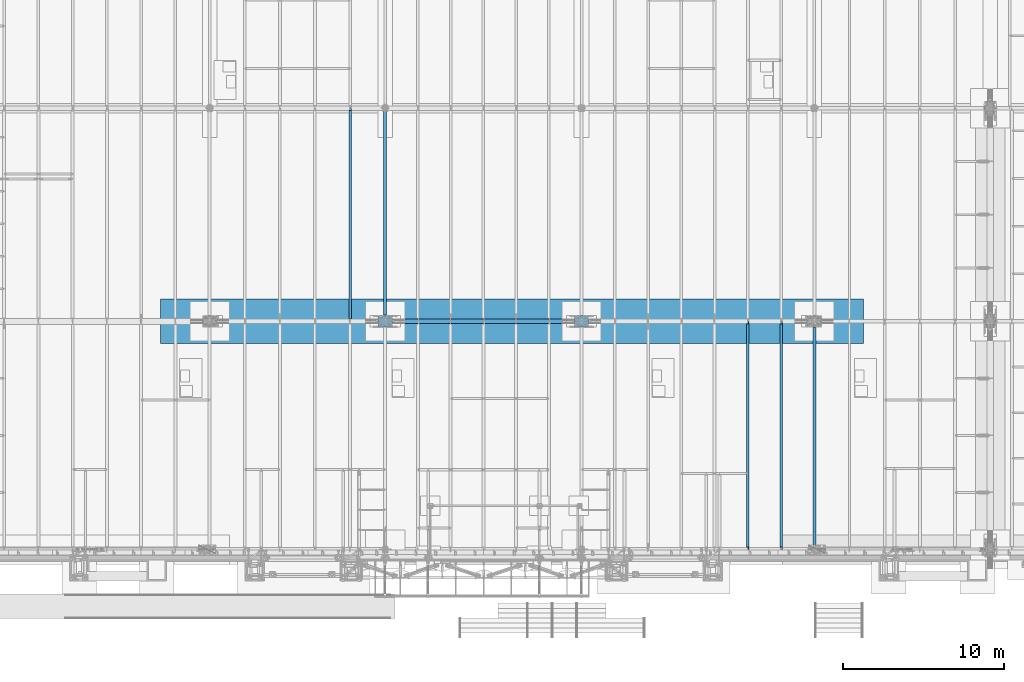
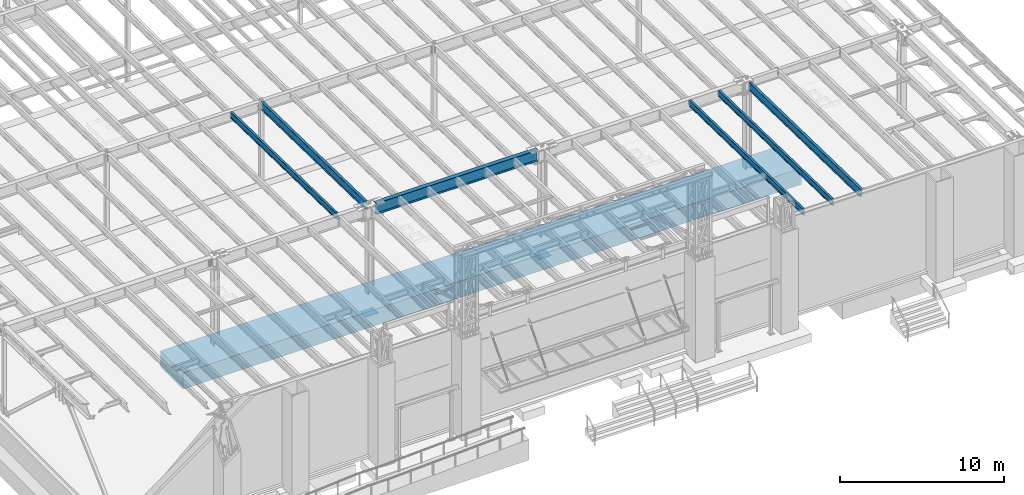
# One storey, part 1067 of 1763: 9 beams, 9 elements without a shape of their own.
"""IFC2X3 building model written with IfcOpenShell, lengths in millimetres."""

from ifc_helpers import new_model, si_unit, frame, origin_with_axes, place, context, subcontext, project, spatial, faceted_brep, material, type_object, element, aggregate, save


model = new_model("IFC2X3")

# Units and contexts
model_context = context("Model", 3, precision=1e-05, world=origin_with_axes())
body_context = subcontext(model_context, "Body", "Model", "MODEL_VIEW")
ifc_project = project(units=[si_unit("LENGTHUNIT", "METRE", prefix="MILLI"), si_unit("AREAUNIT", "SQUARE_METRE"), si_unit("VOLUMEUNIT", "CUBIC_METRE"), si_unit("MASSUNIT", "GRAM", prefix="KILO"), si_unit("TIMEUNIT", "SECOND"), si_unit("PLANEANGLEUNIT", "RADIAN"), si_unit("SOLIDANGLEUNIT", "STERADIAN"), si_unit("THERMODYNAMICTEMPERATUREUNIT", "DEGREE_CELSIUS"), si_unit("LUMINOUSINTENSITYUNIT", "LUMEN")], contexts=[model_context])

# Site, building, storey
site_placement = place(None, origin_with_axes())
site = spatial("IfcSite", under=ifc_project, at=site_placement, CompositionType="ELEMENT")
building_placement = place(site_placement, origin_with_axes())
building = spatial("IfcBuilding", under=site, at=building_placement, Name="Undefined", CompositionType="ELEMENT")
storey_placement = place(building_placement, origin_with_axes())
storey = spatial("IfcBuildingStorey", under=building, at=storey_placement, Name="Undefined", CompositionType="ELEMENT", Elevation=0.0)

# Assembly, beam
assembly_1_placement = place(storey_placement, origin_with_axes())
assembly_1 = element("IfcElementAssembly", 1, at=assembly_1_placement, inside=storey, Name="BEAM", AssemblyPlace="NOTDEFINED", PredefinedType="RIGID_FRAME")
ifc_material_1 = material(Name="STEEL/A992")
beam_type_1 = type_object("IfcBeamType", Name="W18X35", PredefinedType="NOTDEFINED")
beam_1_placement = place(assembly_1_placement, frame((-37014.4944165555, -13720.7116289025, 11979.324245716), z_axis=(0.0, 0.0209013539966291, 0.999781542838788), x_axis=(0.0, 0.999781542776098, -0.0209013569953182)))
beam_1 = element("IfcBeam", 2, at=beam_1_placement, type_object=beam_type_1, material=ifc_material_1, Name="BEAM", ObjectType="W18X35", context=body_context, shape_type="Brep", body=[
    faceted_brep([(14015.111475978, 4.2688297624336, -214.312500004788), (14015.111475978, 4.26866734583018, -225.425000004798), (14015.1114709427, 76.1999999999971, -225.425000004796), (14015.1114709427, 76.1999999999971, -214.312500004788), (14165.6627009912, 4.26875000000291, -215.308088836937), (14165.8742043575, 4.26867789952666, -225.425000004847), (14064.0196871856, 4.26875000000291, -214.312500004802), (14064.0848962425, 4.26875000000291, -217.431666606117), (129.869102983521, 76.1999999999971, -214.312500000213), (130.101420053361, 76.1999999999971, -225.425000000221), (130.101420053361, 4.56874999999854, -225.425000000221), (129.869102983521, 4.56874999999854, -214.312500000213), (30.0675669374232, 4.56874999999854, -225.42500000019), (29.8352498675831, 4.56874999999854, -214.31250000018), (152.354849235744, 3.96875, 214.312500000126), (152.354849235744, 76.1999999999971, 214.312500000126), (14015.1114866801, 76.1999999999971, 214.312499995558), (14015.1114866801, 3.96875, 214.312499995558), (152.354849235751, -76.1999999999971, 225.425000000134), (152.354849235751, 76.1999999999971, 225.425000000134), (152.354849235735, 3.96875, 180.714997673213), (152.354849235735, -3.96875, 180.714997673213), (152.354849235744, -3.96875, 214.312500000126), (152.354849235744, -76.1999999999971, 214.312500000126), (151.388119313144, 3.96875, 175.854918155155), (151.388119313144, -3.96875, 175.854918155155), (148.635105412657, 3.96875, 171.734741686994), (148.635105412657, -3.96875, 171.734741686994), (144.514928944493, 3.96875, 168.98172778651), (144.514928944493, -3.96875, 168.98172778651), (139.654849426437, 3.96875, 168.01499786392), (139.654849426437, -3.96875, 168.01499786392), (21.8423406191578, 3.96875, 168.01499786396), (21.8423406191578, -3.96875, 168.01499786396), (29.8352498675831, 3.96875, -214.31250000018), (30.0675669374232, -76.1999999999971, -225.42500000019), (29.8352498675831, -76.1999999999971, -214.31250000018), (29.8352498675831, -3.96875, -214.31250000018), (14165.8742043575, -76.1999999999971, -225.425000004847), (14165.6418872877, -76.1999999999971, -214.312500004837), (14165.6418872877, -3.96875, -214.312500004837), (14022.9514069713, -3.96875, 168.981727663589), (14018.8312305032, -3.96875, 171.734741564072), (14016.0782166027, -3.96875, 175.854918032239), (14015.1114866801, -3.96875, 180.714997550294), (14015.1114866801, -3.96875, 214.312499995558), (14157.6489780418, -3.96875, 168.014997741), (14027.8114864894, -3.96875, 168.014997740998), (14015.1114866801, -76.1999999999971, 214.312499995558), (14015.1114866801, -76.1999999999971, 225.424999995566), (14015.1114866801, 76.1999999999971, 225.424999995566), (14015.1114866801, 3.96875, 180.714997550294), (14016.0782166027, 3.96875, 175.854918032239), (14018.8312305032, 3.96875, 171.734741564072), (14022.9514069713, 3.96875, 168.981727663589), (14027.8114864894, 3.96875, 168.014997740998), (14157.6489780418, 3.96875, 168.014997741), (14165.6418872877, 3.96875, -214.312500004837), (14165.6418872877, 4.26875000000291, -214.312500004837)], [[[0, 1, 2, 3]], [[4, 5, 1, 0, 6, 7]], [[8, 9, 10, 11]], [[11, 10, 12, 13]], [[14, 15, 16, 17]], [[18, 19, 15, 14, 20, 21, 22, 23]], [[21, 20, 24, 25]], [[25, 24, 26, 27]], [[27, 26, 28, 29]], [[29, 28, 30, 31]], [[31, 30, 32, 33]], [[34, 13, 12, 35, 36, 37, 33, 32]], [[36, 35, 38, 39]], [[37, 36, 39, 40]], [[41, 42, 43, 44, 45, 22, 21, 25, 27, 29, 31, 33, 37, 40, 46, 47]], [[23, 22, 45, 48]], [[18, 23, 48, 49]], [[19, 18, 49, 50]], [[15, 19, 50, 16]], [[49, 48, 45, 44, 51, 17, 16, 50]], [[43, 52, 51, 44]], [[42, 53, 52, 43]], [[41, 54, 53, 42]], [[47, 55, 54, 41]], [[46, 56, 55, 47]], [[57, 34, 32, 30, 28, 26, 24, 20, 14, 17, 51, 52, 53, 54, 55, 56]], [[58, 4, 7, 6]], [[3, 8, 11, 13, 34, 57, 58, 6, 0]], [[9, 8, 3, 2]], [[38, 35, 12, 10, 9, 2, 1, 5]], [[58, 57, 56, 46, 40, 39, 38, 5, 4]]]),
])
aggregate(assembly_1, [beam_1])

assembly_2_placement = place(storey_placement, origin_with_axes())
assembly_2 = element("IfcElementAssembly", 3, at=assembly_2_placement, inside=storey, Name="BEAM", AssemblyPlace="NOTDEFINED", PredefinedType="RIGID_FRAME")
beam_2_placement = place(assembly_2_placement, frame((-39079.1515594126, -13720.7116289377, 11979.324245716), z_axis=(0.0, 0.0209013539966291, 0.999781542838788), x_axis=(0.0, 0.999781542776098, -0.0209013569953182)))
beam_2 = element("IfcBeam", 4, at=beam_2_placement, type_object=beam_type_1, material=ifc_material_1, Name="BEAM", ObjectType="W18X35", context=body_context, shape_type="Brep", body=[
    faceted_brep([(14015.111475978, 4.2688297624336, -214.312500004788), (14015.111475978, 4.26866734583018, -225.425000004798), (14015.1114709427, 76.1999999999971, -225.425000004796), (14015.1114709427, 76.1999999999971, -214.312500004788), (14165.6418873229, 4.26884030015208, -214.312500004839), (14165.8742043575, 4.26867789952666, -225.425000004847), (129.869102983521, 76.1999999999971, -214.312500000213), (130.101420053361, 76.1999999999971, -225.425000000221), (130.101420053361, 4.56874999999854, -225.425000000221), (129.869102983521, 4.56874999999854, -214.312500000213), (30.0675669374232, 4.56874999999854, -225.42500000019), (29.8352498675831, 4.56874999999854, -214.31250000018), (152.354849235744, 3.96875, 214.312500000126), (152.354849235744, 76.1999999999971, 214.312500000126), (14015.1114866801, 76.1999999999971, 214.312499995558), (14015.1114866801, 3.96875, 214.312499995558), (152.354849235751, -76.1999999999971, 225.425000000134), (152.354849235751, 76.1999999999971, 225.425000000134), (152.354849235735, 3.96875, 180.714997673213), (152.354849235735, -3.96875, 180.714997673213), (152.354849235744, -3.96875, 214.312500000126), (152.354849235744, -76.1999999999971, 214.312500000126), (151.388119313144, 3.96875, 175.854918155155), (151.388119313144, -3.96875, 175.854918155155), (148.635105412657, 3.96875, 171.734741686994), (148.635105412657, -3.96875, 171.734741686994), (144.514928944493, 3.96875, 168.98172778651), (144.514928944493, -3.96875, 168.98172778651), (139.654849426437, 3.96875, 168.01499786392), (139.654849426437, -3.96875, 168.01499786392), (21.8423406191578, 3.96875, 168.01499786396), (21.8423406191578, -3.96875, 168.01499786396), (29.8352498675831, 3.96875, -214.31250000018), (30.0675669374232, -76.1999999999971, -225.42500000019), (29.8352498675831, -76.1999999999971, -214.31250000018), (29.8352498675831, -3.96875, -214.31250000018), (14165.8742043575, -76.1999999999971, -225.425000004847), (14165.6418872877, -76.1999999999971, -214.312500004837), (14165.6418872877, -3.96875, -214.312500004837), (14022.9514069713, -3.96875, 168.981727663589), (14018.8312305032, -3.96875, 171.734741564072), (14016.0782166027, -3.96875, 175.854918032239), (14015.1114866801, -3.96875, 180.714997550294), (14015.1114866801, -3.96875, 214.312499995558), (14157.6489780418, -3.96875, 168.014997741), (14027.8114864894, -3.96875, 168.014997740998), (14015.1114866801, -76.1999999999971, 214.312499995558), (14015.1114866801, -76.1999999999971, 225.424999995566), (14015.1114866801, 76.1999999999971, 225.424999995566), (14015.1114866801, 3.96875, 180.714997550294), (14016.0782166027, 3.96875, 175.854918032239), (14018.8312305032, 3.96875, 171.734741564072), (14022.9514069713, 3.96875, 168.981727663589), (14027.8114864894, 3.96875, 168.014997740998), (14157.6489780418, 3.96875, 168.014997741), (14165.6418872877, 3.96875, -214.312500004837)], [[[0, 1, 2, 3]], [[4, 5, 1, 0]], [[6, 7, 8, 9]], [[9, 8, 10, 11]], [[12, 13, 14, 15]], [[16, 17, 13, 12, 18, 19, 20, 21]], [[19, 18, 22, 23]], [[23, 22, 24, 25]], [[25, 24, 26, 27]], [[27, 26, 28, 29]], [[29, 28, 30, 31]], [[32, 11, 10, 33, 34, 35, 31, 30]], [[34, 33, 36, 37]], [[35, 34, 37, 38]], [[39, 40, 41, 42, 43, 20, 19, 23, 25, 27, 29, 31, 35, 38, 44, 45]], [[21, 20, 43, 46]], [[16, 21, 46, 47]], [[17, 16, 47, 48]], [[13, 17, 48, 14]], [[47, 46, 43, 42, 49, 15, 14, 48]], [[41, 50, 49, 42]], [[40, 51, 50, 41]], [[39, 52, 51, 40]], [[45, 53, 52, 39]], [[44, 54, 53, 45]], [[55, 32, 30, 28, 26, 24, 22, 18, 12, 15, 49, 50, 51, 52, 53, 54]], [[3, 6, 9, 11, 32, 55, 4, 0]], [[7, 6, 3, 2]], [[36, 33, 10, 8, 7, 2, 1, 5]], [[55, 54, 44, 38, 37, 36, 5, 4]]]),
])
aggregate(assembly_2, [beam_2])

assembly_3_placement = place(storey_placement, origin_with_axes())
assembly_3 = element("IfcElementAssembly", 5, at=assembly_3_placement, inside=storey, Name="BEAM", AssemblyPlace="NOTDEFINED", PredefinedType="RIGID_FRAME")
beam_type_2 = type_object("IfcBeamType", Name="W18X40", PredefinedType="NOTDEFINED")
beam_3_placement = place(assembly_3_placement, frame((-63773.7572736983, 452.455130930327, 11681.4332640109), z_axis=(0.0, 0.0209013539966291, 0.999781542838788), x_axis=(0.0, 0.999781542776098, -0.0209013569953182)))
beam_3 = element("IfcBeam", 6, at=beam_3_placement, type_object=beam_type_2, material=ifc_material_1, Name="BEAM", ObjectType="W18X40", context=body_context, shape_type="Brep", body=[
    faceted_brep([(29.0743924101943, -3.96875, -214.31250000018), (29.3398976328791, -3.96867297649442, -227.01250000019), (172.24808792756, -3.9686593998631, -227.012500000241), (172.248087927576, -3.96875, -214.312500000231), (172.2480947897, -76.1999999999971, -214.312500000231), (172.248094789697, -76.1999999999971, -227.012500000241), (13125.1458004226, 4.26884714065818, -214.312500004715), (13125.1458004227, 4.268649864287, -227.012500004723), (13125.1457929416, 76.1999999999971, -227.012500004725), (13125.1457929416, 76.1999999999971, -214.312500004715), (172.248086396876, 76.1999999999971, -227.012500000241), (172.24808639688, 76.1999999999971, -214.312500000231), (172.248093258896, 3.96884671709995, -227.012500000241), (172.248093258908, 3.96865936378163, -214.312500001566), (80.1509976836787, 3.96924991607375, -227.01250000021), (79.8854924610018, 3.96875, -214.3125000002), (29.3398976328791, 3.96924991607375, -227.01250000019), (29.0743924101943, 3.96875, -214.31250000018), (172.248085922071, 3.96875, 214.312500000111), (172.248085922071, 76.1999999999971, 214.312500000111), (13088.6333065581, 76.1999999999971, 214.31249999564), (13088.6333065581, 3.96875, 214.31249999564), (13226.4637071899, 3.96875, -214.312500004749), (28.6761568530486, 3.96875, -195.263565576959), (21.0428594241718, 3.96875, 169.862499999928), (159.54808611285, 3.96875, 169.86249999993), (164.408165630896, 3.96875, 170.829229922516), (168.52834209905, 3.96875, 173.582243823001), (171.281355999526, 3.96875, 177.702420291163), (172.248085922111, 3.96875, 182.562499809223), (13088.6333065582, 3.96875, 195.002501414689), (13089.6000364807, 3.96875, 190.142421896631), (13092.3530503812, 3.96875, 186.022245428465), (13096.4732268494, 3.96875, 183.269231527978), (13101.3333063674, 3.96875, 182.302501605383), (13218.1721044876, 3.96875, 182.302501605345), (13226.4637071899, 4.26885767801286, -214.312500004749), (13226.7292124126, 4.26866042923211, -227.012500004759), (13218.1721044876, -3.96875, 182.302501605345), (13226.4637071899, -3.96875, -214.312500004749), (13226.4637071899, -76.1999999999971, -214.312500004749), (13226.7292124126, -76.1999999999971, -227.012500004759), (28.6761593004586, -3.96875, -195.263682644741), (21.0428594241718, -3.96875, 169.862499999928), (159.54808611285, -3.96875, 169.86249999993), (164.408165630896, -3.96875, 170.829229922516), (168.52834209905, -3.96875, 173.582243823001), (171.281355999526, -3.96875, 177.702420291163), (172.248085922111, -3.96875, 182.562499809223), (172.24808592207, -76.1999999999971, 227.012500000121), (172.24808592207, 76.1999999999971, 227.012500000121), (172.248085922071, -3.96875, 214.312500000111), (172.248085922071, -76.1999999999971, 214.312500000111), (13088.6333065581, -3.96875, 214.31249999564), (13088.6333065581, -76.1999999999971, 214.31249999564), (13088.6333065581, -76.1999999999971, 227.01249999565), (13088.6333065581, 76.1999999999971, 227.01249999565), (13088.6333065582, -3.96875, 195.002501414689), (13089.6000364807, -3.96875, 190.142421896631), (13092.3530503812, -3.96875, 186.022245428465), (13096.4732268494, -3.96875, 183.269231527978), (13101.3333063674, -3.96875, 182.302501605383)], [[[0, 1, 2, 3]], [[4, 3, 2, 5]], [[6, 7, 8, 9]], [[10, 11, 9, 8]], [[11, 10, 12, 13]], [[13, 12, 14, 15]], [[16, 17, 15, 14]], [[18, 19, 20, 21]], [[22, 13, 15, 17, 23, 24, 25, 26, 27, 28, 29, 18, 21, 30, 31, 32, 33, 34, 35]], [[9, 11, 13, 22, 36, 6]], [[37, 7, 6, 36]], [[22, 35, 38, 39, 40, 41, 37, 36]], [[41, 40, 4, 5]], [[1, 16, 14, 12, 10, 8, 7, 37, 41, 5, 2]], [[42, 43, 24, 23, 17, 16, 1, 0]], [[44, 25, 24, 43]], [[45, 26, 25, 44]], [[46, 27, 26, 45]], [[47, 28, 27, 46]], [[48, 29, 28, 47]], [[49, 50, 19, 18, 29, 48, 51, 52]], [[52, 51, 53, 54]], [[49, 52, 54, 55]], [[50, 49, 55, 56]], [[19, 50, 56, 20]], [[55, 54, 53, 57, 30, 21, 20, 56]], [[58, 31, 30, 57]], [[59, 32, 31, 58]], [[60, 33, 32, 59]], [[61, 34, 33, 60]], [[38, 35, 34, 61]], [[60, 59, 58, 57, 53, 51, 48, 47, 46, 45, 44, 43, 42, 0, 3, 39, 38, 61]], [[40, 39, 3, 4]]]),
])
aggregate(assembly_3, [beam_3])

assembly_4_placement = place(storey_placement, origin_with_axes())
assembly_4 = element("IfcElementAssembly", 7, at=assembly_4_placement, inside=storey, Name="BEAM", AssemblyPlace="NOTDEFINED", PredefinedType="RIGID_FRAME")
beam_type_3 = type_object("IfcBeamType", Name="W24X55", PredefinedType="NOTDEFINED")
beam_4_placement = place(assembly_4_placement, frame((-34949.8372736984, -13722.2711313756, 11904.7280453544), z_axis=(0.0, 0.0209013539966291, 0.999781542838788), x_axis=(0.0, 0.999781542776098, -0.0209013569953182)))
beam_4 = element("IfcBeam", 8, at=beam_4_placement, type_object=beam_type_3, material=ifc_material_1, Name="BEAM", ObjectType="W24X55", context=body_context, shape_type="Brep", body=[
    faceted_brep([(126.604532426318, -4.76249999999709, -287.337500000274), (126.870037648992, -4.76250305176654, -300.037500000284), (253.604532426827, -4.7625030517811, -300.037500000324), (253.604532426833, -4.76249999999709, -287.337500000316), (253.604532426831, -88.9000000000087, -287.337500000316), (253.604532426829, -88.9000000000015, -300.037500000324), (13798.3436364725, 5.0626101401067, -287.337500004778), (13798.3436364727, 5.06238686235156, -300.03750000479), (13798.3435518805, 88.9000000000015, -300.037500004788), (13798.3435518805, 88.9000000000015, -287.337500004778), (253.604532426836, 88.9000000000015, -300.037500000324), (253.604532426838, 88.9000000000015, -287.337500000316), (114.590421100289, 4.76249999999709, 287.337500000192), (114.590421100289, 88.9000000000015, 287.337500000192), (13798.3437883337, 88.9000000000015, 287.337499995683), (13798.3437883337, 4.76249999999709, 287.337499995683), (13956.750841961, 4.76249999999709, -287.337500004831), (253.604532426838, 4.76250305175927, -287.337500000316), (126.604532426318, 4.76249999999709, -287.337500000274), (13798.3437883337, 4.76249999999709, 261.677501479031), (13799.3105182563, 4.76249999999709, 256.817421960977), (13802.0635321568, 4.76249999999709, 252.697245492813), (13806.183708625, 4.76249999999709, 249.944231592328), (13811.043788143, 4.76249999999709, 248.977501669737), (13945.5386855639, 4.76249999999709, 248.97750166974), (253.604532426834, 4.76250305175927, -300.037500000324), (126.870037648992, 4.76250305175927, -300.037500000284), (13956.750841961, 5.06276997307577, -287.337500004831), (13957.0163470948, 5.06254696322867, -300.037500004843), (13945.5386855639, -4.76249999999709, 248.97750166974), (13956.750841961, -4.76249999999709, -287.337500004831), (13956.750841961, -5.06222699052159, -287.337500004831), (13957.0163470948, -5.0624500003687, -300.037500004843), (13798.3436986942, -5.06238682331605, -287.337500004778), (13798.3436986944, -5.06261010107119, -300.03750000479), (13798.3437832867, -88.9000000000015, -287.33750000478), (13798.3437832867, -88.9000000000015, -300.03750000479), (114.590421100289, -4.76249999999709, 287.337500000192), (114.590421100289, -88.9000000000015, 287.337500000192), (114.324915877614, -88.9000000000015, 300.0375000002), (114.324915877614, 88.9000000000015, 300.0375000002), (13798.3437883337, -4.76249999999709, 287.337499995683), (13798.3437883337, -88.9000000000015, 287.337499995683), (13798.3437883337, -88.9000000000015, 300.037499995693), (13798.3437883337, 88.9000000000015, 300.037499995693), (13798.3437883337, -4.76249999999709, 261.677501479031), (13799.3105182563, -4.76249999999709, 256.817421960977), (13802.0635321568, -4.76249999999709, 252.697245492813), (13806.183708625, -4.76249999999709, 249.944231592328), (13811.043788143, -4.76249999999709, 248.977501669737)], [[[0, 1, 2, 3]], [[4, 3, 2, 5]], [[6, 7, 8, 9]], [[9, 8, 10, 11]], [[12, 13, 14, 15]], [[16, 17, 18, 12, 15, 19, 20, 21, 22, 23, 24]], [[17, 25, 26, 18]], [[11, 10, 25, 17]], [[16, 27, 6, 9, 11, 17]], [[28, 7, 6, 27]], [[16, 24, 29, 30, 31, 32, 28, 27]], [[32, 31, 33, 34]], [[35, 36, 34, 33]], [[36, 35, 4, 5]], [[1, 26, 25, 10, 8, 7, 28, 32, 34, 36, 5, 2]], [[37, 38, 39, 40, 13, 12, 18, 26, 1, 0]], [[38, 37, 41, 42]], [[39, 38, 42, 43]], [[40, 39, 43, 44]], [[13, 40, 44, 14]], [[43, 42, 41, 45, 19, 15, 14, 44]], [[46, 20, 19, 45]], [[47, 21, 20, 46]], [[48, 22, 21, 47]], [[49, 23, 22, 48]], [[29, 24, 23, 49]], [[48, 47, 46, 45, 41, 37, 0, 3, 30, 29, 49]], [[35, 33, 31, 30, 3, 4]]]),
])
aggregate(assembly_4, [beam_4])

assembly_5_placement = place(storey_placement, origin_with_axes())
assembly_5 = element("IfcElementAssembly", 9, at=assembly_5_placement, inside=storey, Name="BEAM", AssemblyPlace="NOTDEFINED", PredefinedType="RIGID_FRAME")
beam_5_placement = place(assembly_5_placement, frame((-61594.4372736983, 450.92880941152, 11608.424216848), z_axis=(0.0, 0.0209013539966291, 0.999781542838788), x_axis=(0.0, 0.999781542776098, -0.0209013569953182)))
beam_5 = element("IfcBeam", 10, at=beam_5_placement, type_object=beam_type_3, material=ifc_material_1, Name="BEAM", ObjectType="W24X55", context=body_context, shape_type="Brep", body=[
    faceted_brep([(261.57157216741, -5.0627973124283, -287.337500000318), (261.83707730115, -5.06255785236863, -300.03750000033), (407.964704054426, -5.06237884570146, -300.037500000377), (407.964704054714, -5.06261798056221, -287.337500000369), (407.964806755689, -88.9000000000015, -287.337500000369), (407.964806755688, -88.9000000000015, -300.037500000381), (395.264518516618, -4.76249999999709, 261.677501485332), (395.264518516618, 4.76249999999709, 261.677501485332), (394.297788594033, 4.76249999999709, 256.817421967275), (394.297788594033, -4.76249999999709, 256.817421967275), (391.544774693557, 4.76249999999709, 252.69724549911), (391.544774693557, -4.76249999999709, 252.69724549911), (387.424598225404, 4.76249999999709, 249.944231598627), (387.424598225404, -4.76249999999709, 249.944231598627), (382.564518707357, 4.76249999999709, 248.977501676041), (382.564518707357, -4.76249999999709, 248.977501676041), (250.359415770033, 4.76249999999709, 248.97750167604), (250.359415770033, -4.76249999999709, 248.97750167604), (261.57157216741, -4.76249999999709, -287.337500000318), (13108.8406546312, -4.76249999999709, -287.337500004767), (13096.826543305, -4.76249999999709, 287.337499995696), (395.264518516582, -4.76249999999709, 287.337500000092), (13096.826543305, 88.9000000000015, 287.337499995696), (13096.826543305, 4.76249999999709, 287.337499995696), (395.264518516582, 4.76249999999709, 287.337500000092), (395.264518516582, 88.9000000000015, 287.337500000092), (13096.5610380823, 88.9000000000015, 300.037499995706), (395.264518516582, 88.9000000000015, 300.037500000104), (13096.5610380823, -88.9000000000015, 300.037499995706), (395.264518516582, -88.9000000000015, 300.037500000104), (13096.826543305, -88.9000000000015, 287.337499995696), (395.264518516582, -88.9000000000015, 287.337500000092), (13108.8406546312, 4.76249999999709, -287.337500004767), (261.57157216741, 4.76249999999709, -287.337500000318), (13108.8406546312, 88.9000000000015, -287.337500004767), (407.964524642031, 88.9000000000015, -287.337500000369), (407.964627342688, 5.06237889974727, -287.337500000371), (261.57157216741, 5.06219956830319, -287.337500000318), (407.9646273424, 5.06261803460075, -300.037500000379), (261.83707730115, 5.06243902836286, -300.03750000033), (407.964524642027, 88.9000000000015, -300.037500000381), (13109.1061598539, 88.9000000000015, -300.037500004775), (13108.8406546312, -88.9000000000015, -287.337500004767), (13109.1061598539, -88.9000000000015, -300.037500004775)], [[[0, 1, 2, 3]], [[4, 3, 2, 5]], [[6, 7, 8, 9]], [[9, 8, 10, 11]], [[11, 10, 12, 13]], [[13, 12, 14, 15]], [[15, 14, 16, 17]], [[9, 11, 13, 15, 17, 18, 19, 20, 21, 6]], [[22, 23, 24, 25]], [[26, 22, 25, 27]], [[28, 26, 27, 29]], [[30, 28, 29, 31]], [[20, 30, 31, 21]], [[29, 27, 25, 24, 7, 6, 21, 31]], [[23, 32, 33, 16, 14, 12, 10, 8, 7, 24]], [[33, 32, 34, 35, 36, 37]], [[36, 38, 39, 37]], [[35, 40, 38, 36]], [[34, 41, 40, 35]], [[32, 23, 22, 26, 28, 30, 20, 19, 42, 43, 41, 34]], [[43, 42, 4, 5]], [[1, 39, 38, 40, 41, 43, 5, 2]], [[18, 17, 16, 33, 37, 39, 1, 0]], [[42, 19, 18, 0, 3, 4]]]),
])
aggregate(assembly_5, [beam_5])

assembly_6_placement = place(storey_placement, origin_with_axes())
assembly_6 = element("IfcElementAssembly", 11, at=assembly_6_placement, inside=storey, Name="STRIP FOOTING", AssemblyPlace="NOTDEFINED", PredefinedType="REINFORCEMENT_UNIT")
ifc_material_2 = material(Name="CONCRETE/5000")
beam_type_4 = type_object("IfcBeamType", PredefinedType="NOTDEFINED")
beam_6_placement = place(assembly_6_placement, frame((-75539.0372736983, 457.2, 4419.6), z_axis=(0.0, 0.0, 1.0), x_axis=(1.0, 0.0, 0.0)))
beam_6 = element("IfcBeam", 12, at=beam_6_placement, type_object=beam_type_4, material=ifc_material_2, Name="STRIP FOOTING", context=body_context, shape_type="Brep", body=[
    faceted_brep([(0.0, 1371.6, -609.6), (0.0, 1371.6, 609.6), (43637.2, 1371.6, 609.6), (43637.2, 1371.6, -609.6), (0.0, -1371.6, 609.6), (43637.2, -1371.6, 609.6), (0.0, -1371.6, -609.6), (43637.2, -1371.6, -609.6)], [[[0, 1, 2, 3]], [[1, 4, 5, 2]], [[4, 6, 7, 5]], [[6, 0, 3, 7]], [[5, 7, 3, 2]], [[6, 4, 1, 0]]]),
])
aggregate(assembly_6, [beam_6])

assembly_7_placement = place(storey_placement, origin_with_axes())
assembly_7 = element("IfcElementAssembly", 13, at=assembly_7_placement, inside=storey, Name="TEMPLATE", AssemblyPlace="NOTDEFINED", PredefinedType="RIGID_FRAME")
ifc_material_3 = material(Name="STEEL/A36")
beam_type_5 = type_object("IfcBeamType", PredefinedType="NOTDEFINED")
beam_7_placement = place(assembly_7_placement, frame((-61149.9372736986, 457.200000000006, 3851.275), z_axis=(0.0, -1.0, 0.0), x_axis=(-1.0, 0.0, 0.0)))
beam_7 = element("IfcBeam", 14, at=beam_7_placement, type_object=beam_type_5, material=ifc_material_3, Name="TEMPLATE", context=body_context, shape_type="Brep", body=[
    faceted_brep([(0.0, 3.17500000000018, -355.599999999999), (0.0, 3.17500000000018, 355.599999999999), (889.0, 3.17500000000018, 355.599999999999), (889.0, 3.17500000000018, -355.599999999999), (0.0, -3.17500000000018, 355.599999999999), (889.0, -3.17500000000018, 355.599999999999), (0.0, -3.17500000000018, -355.599999999999), (889.0, -3.17500000000018, -355.599999999999)], [[[0, 1, 2, 3]], [[1, 4, 5, 2]], [[4, 6, 7, 5]], [[6, 0, 3, 7]], [[5, 7, 3, 2]], [[6, 4, 1, 0]]]),
])
aggregate(assembly_7, [beam_7])

assembly_8_placement = place(storey_placement, origin_with_axes())
assembly_8 = element("IfcElementAssembly", 15, at=assembly_8_placement, inside=storey, Name="TEMPLATE", AssemblyPlace="NOTDEFINED", PredefinedType="RIGID_FRAME")
beam_8_placement = place(assembly_8_placement, frame((-48957.9372736986, 457.200000000003, 3851.275), z_axis=(0.0, -1.0, 0.0), x_axis=(-1.0, 0.0, 0.0)))
beam_8 = element("IfcBeam", 16, at=beam_8_placement, type_object=beam_type_5, material=ifc_material_3, Name="TEMPLATE", context=body_context, shape_type="Brep", body=[
    faceted_brep([(0.0, 3.17500000000018, -355.599999999999), (0.0, 3.17500000000018, 355.599999999999), (889.0, 3.17500000000018, 355.599999999999), (889.0, 3.17500000000018, -355.599999999999), (0.0, -3.17500000000018, 355.599999999999), (889.0, -3.17500000000018, 355.599999999999), (0.0, -3.17500000000018, -355.599999999999), (889.0, -3.17500000000018, -355.599999999999)], [[[0, 1, 2, 3]], [[1, 4, 5, 2]], [[4, 6, 7, 5]], [[6, 0, 3, 7]], [[5, 7, 3, 2]], [[6, 4, 1, 0]]]),
])
aggregate(assembly_8, [beam_8])

assembly_9_placement = place(storey_placement, origin_with_axes())
assembly_9 = element("IfcElementAssembly", 17, at=assembly_9_placement, inside=storey, Name="BEAM", AssemblyPlace="NOTDEFINED", PredefinedType="RIGID_FRAME")
beam_type_6 = type_object("IfcBeamType", Name="W33X130", PredefinedType="NOTDEFINED")
beam_9_placement = place(assembly_9_placement, frame((-61594.4372736983, 457.200000000003, 11487.7086714953), z_axis=(0.0, 0.0, 1.0), x_axis=(1.0, 0.0, 0.0)))
beam_9 = element("IfcBeam", 18, at=beam_9_placement, type_object=beam_type_6, material=ifc_material_1, Name="BEAM", ObjectType="W33X130", context=body_context, shape_type="Brep", body=[
    faceted_brep([(11810.9999999997, 41.2749999999983, -398.4625), (11666.5375032422, 41.2749999999983, -398.4625), (11666.5375032422, 41.2749999999983, -420.6875), (11810.9999999997, 41.2749999999983, -420.6875), (11662.2849335271, 40.4291112905111, -398.4625), (11662.2849335271, 40.4291112905111, -420.6875), (11658.6797790014, 38.0202240500688, -398.4625), (11658.6797790014, 38.0202240500688, -420.6875), (11656.270891761, 34.4150695244115, -398.4625), (11656.270891761, 34.4150695244115, -420.6875), (11655.4250030515, 30.1624998092634, -398.4625), (11655.4250030515, 30.1624998092634, -420.6875), (11656.270891761, 25.9099300941153, -398.4625), (11656.270891761, 25.9099300941153, -420.6875), (11658.6797790014, 22.304775568458, -398.4625), (11658.6797790014, 22.304775568458, -420.6875), (11662.2849335271, 19.8958883280157, -398.4625), (11662.2849335271, 19.8958883280157, -420.6875), (11666.5375032422, 19.0499996185285, -398.4625), (11666.5375032422, 19.0499996185285, -420.6875), (11810.9999999997, 19.0499996185285, -398.4625), (11810.9999999997, 19.0499996185285, -420.6875), (380.999999999724, 146.05, -420.6875), (380.999999999724, 146.05, -398.4625), (11810.9999999997, 146.05, -398.4625), (11810.9999999997, 146.05, -420.6875), (380.999999999724, 41.2749999999983, -420.6875), (380.999999999724, 41.2749999999983, -398.4625), (525.462496757231, 41.2749999999983, -420.6875), (525.462496757231, 41.2749999999983, -398.4625), (529.715066472381, 40.4291112905111, -420.6875), (529.715066472381, 40.4291112905111, -398.4625), (533.320220998037, 38.0202240500688, -420.6875), (533.320220998037, 38.0202240500688, -398.4625), (535.729108238476, 34.4150695244115, -420.6875), (535.729108238476, 34.4150695244115, -398.4625), (536.574996947966, 30.1624998092634, -420.6875), (536.574996947966, 30.1624998092634, -398.4625), (535.729108238476, 25.9099300941153, -420.6875), (535.729108238476, 25.9099300941153, -398.4625), (533.320220998037, 22.304775568458, -420.6875), (533.320220998037, 22.304775568458, -398.4625), (529.715066472381, 19.8958883280157, -420.6875), (529.715066472381, 19.8958883280157, -398.4625), (525.462496757231, 19.0499996185285, -420.6875), (525.462496757231, 19.0499996185285, -398.4625), (380.999999999724, 19.0499996185285, -420.6875), (380.999999999724, 19.0499996185285, -398.4625), (380.999999999724, -146.05, -420.6875), (380.999999999724, -146.05, -398.4625), (380.999999999724, -7.14375000000001, -398.4625), (380.999999999724, -7.14375000000001, 398.4625), (380.999999999724, -146.05, 398.4625), (380.999999999724, -146.05, 420.6875), (380.999999999724, 146.05, 420.6875), (380.999999999724, 146.05, 398.4625), (380.999999999724, 7.14375000000001, 398.4625), (380.999999999724, 7.14375000000001, -398.4625), (11810.9999999997, -146.05, -420.6875), (11810.9999999997, -146.05, -398.4625), (11810.9999999997, -7.14375000000001, -398.4625), (11810.9999999997, -7.14375000000001, 398.4625), (11810.9999999997, -146.05, 398.4625), (11810.9999999997, -146.05, 420.6875), (11810.9999999997, 146.05, 420.6875), (11810.9999999997, 146.05, 398.4625), (11810.9999999997, 7.14375000000001, 398.4625), (11810.9999999997, 7.14375000000001, -398.4625)], [[[0, 1, 2, 3]], [[4, 5, 2, 1]], [[6, 7, 5, 4]], [[8, 9, 7, 6]], [[10, 11, 9, 8]], [[12, 13, 11, 10]], [[14, 15, 13, 12]], [[16, 17, 15, 14]], [[18, 19, 17, 16]], [[20, 21, 19, 18]], [[22, 23, 24, 25]], [[23, 22, 26, 27]], [[27, 26, 28, 29]], [[29, 28, 30, 31]], [[31, 30, 32, 33]], [[33, 32, 34, 35]], [[35, 34, 36, 37]], [[37, 36, 38, 39]], [[39, 38, 40, 41]], [[41, 40, 42, 43]], [[43, 42, 44, 45]], [[45, 44, 46, 47]], [[48, 49, 50, 51, 52, 53, 54, 55, 56, 57, 47, 46]], [[49, 48, 58, 59]], [[50, 49, 59, 60]], [[51, 50, 60, 61]], [[52, 51, 61, 62]], [[53, 52, 62, 63]], [[54, 53, 63, 64]], [[55, 54, 64, 65]], [[56, 55, 65, 66]], [[57, 56, 66, 67]], [[16, 14, 12, 10, 8, 6, 4, 1, 0, 24, 23, 27, 29, 31, 33, 35, 37, 39, 41, 43, 45, 47, 57, 67, 20, 18]], [[25, 24, 0, 3]], [[58, 48, 46, 44, 42, 40, 38, 36, 34, 32, 30, 28, 26, 22, 25, 3, 2, 5, 7, 9, 11, 13, 15, 17, 19, 21]], [[67, 66, 65, 64, 63, 62, 61, 60, 59, 58, 21, 20]]]),
])
aggregate(assembly_9, [beam_9])

save(model, "model.ifc")
